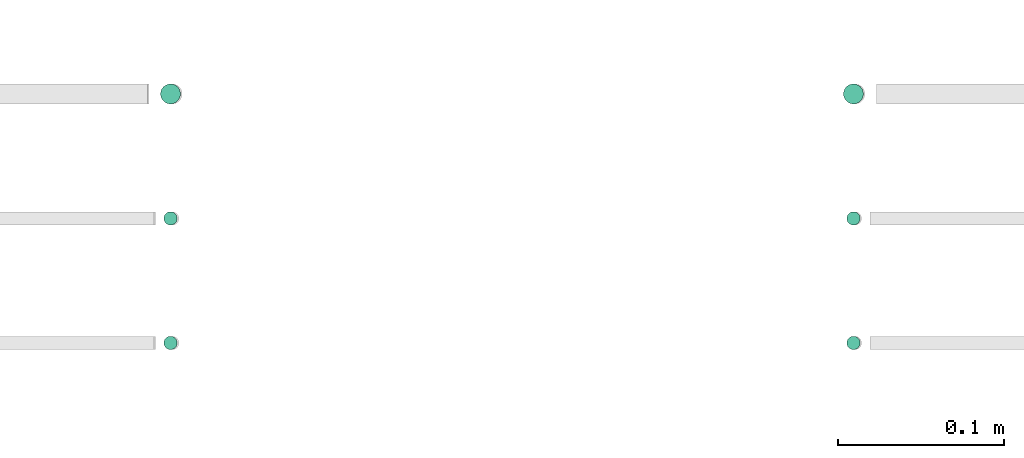
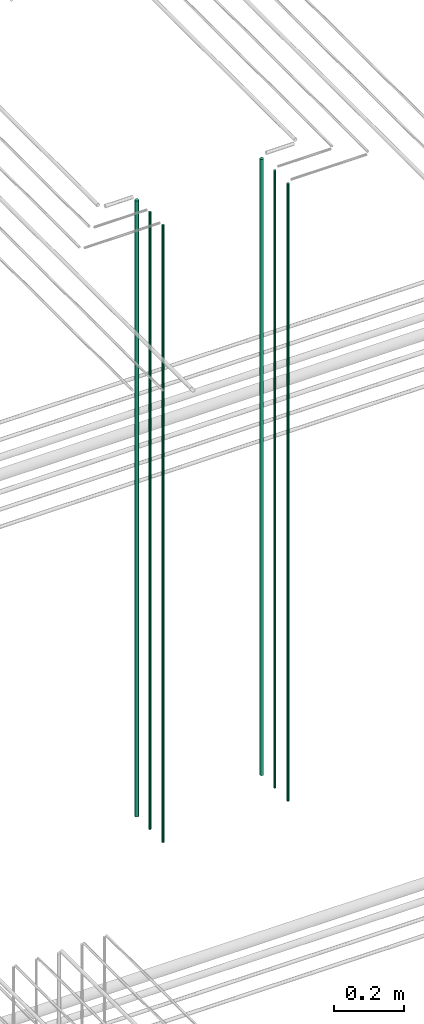
# One storey, part 52 of 331: 6 flow segments.
"""IFC2X3 building model written with IfcOpenShell, lengths in millimetres."""

from ifc_helpers import new_model, entity, si_unit, converted_unit, derived_unit, direction, frame, origin, origin_2d_with_axis, place, context, subcontext, project, spatial, circle, extrude, type_object, element, save


model = new_model("IFC2X3")

# Units and contexts
model_context = context("Model", 3, precision=0.01, world=origin(), true_north=direction((6.12303176911189e-17, 1.0)))
body_context = subcontext(model_context, "Body", "Model", "MODEL_VIEW")
ifc_project = project(units=[si_unit("LENGTHUNIT", "METRE", prefix="MILLI"), si_unit("AREAUNIT", "SQUARE_METRE"), si_unit("VOLUMEUNIT", "CUBIC_METRE"), converted_unit("PLANEANGLEUNIT", "DEGREE", entity("IfcRatioMeasure", 0.0174532925199433), si_unit("PLANEANGLEUNIT", "RADIAN"), dimensions=[0, 0, 0, 0, 0, 0, 0]), si_unit("MASSUNIT", "GRAM", prefix="KILO"), derived_unit("MASSDENSITYUNIT", [(si_unit("MASSUNIT", "GRAM", prefix="KILO"), 1), (si_unit("LENGTHUNIT", "METRE"), -3)]), derived_unit("MOMENTOFINERTIAUNIT", [(si_unit("LENGTHUNIT", "METRE"), 4)]), si_unit("TIMEUNIT", "SECOND"), si_unit("FREQUENCYUNIT", "HERTZ"), si_unit("THERMODYNAMICTEMPERATUREUNIT", "DEGREE_CELSIUS"), derived_unit("THERMALTRANSMITTANCEUNIT", [(si_unit("MASSUNIT", "GRAM", prefix="KILO"), 1), (si_unit("THERMODYNAMICTEMPERATUREUNIT", "KELVIN"), -1), (si_unit("TIMEUNIT", "SECOND"), -3)]), derived_unit("VOLUMETRICFLOWRATEUNIT", [(si_unit("LENGTHUNIT", "METRE"), 3), (si_unit("TIMEUNIT", "SECOND"), -1)]), derived_unit("MASSFLOWRATEUNIT", [(si_unit("MASSUNIT", "GRAM", prefix="KILO"), 1), (si_unit("TIMEUNIT", "SECOND"), -1)]), derived_unit("ROTATIONALFREQUENCYUNIT", [(si_unit("TIMEUNIT", "SECOND"), -1)]), si_unit("ELECTRICCURRENTUNIT", "AMPERE"), si_unit("ELECTRICVOLTAGEUNIT", "VOLT"), si_unit("POWERUNIT", "WATT"), si_unit("FORCEUNIT", "NEWTON", prefix="KILO"), si_unit("ILLUMINANCEUNIT", "LUX"), si_unit("LUMINOUSFLUXUNIT", "LUMEN"), si_unit("LUMINOUSINTENSITYUNIT", "CANDELA"), derived_unit("USERDEFINED", [(si_unit("MASSUNIT", "GRAM", prefix="KILO"), -1), (si_unit("LENGTHUNIT", "METRE"), -2), (si_unit("TIMEUNIT", "SECOND"), 3), (si_unit("LUMINOUSFLUXUNIT", "LUMEN"), 1)]), derived_unit("LINEARVELOCITYUNIT", [(si_unit("LENGTHUNIT", "METRE"), 1), (si_unit("TIMEUNIT", "SECOND"), -1)]), si_unit("PRESSUREUNIT", "PASCAL"), derived_unit("USERDEFINED", [(si_unit("LENGTHUNIT", "METRE"), -2), (si_unit("MASSUNIT", "GRAM", prefix="KILO"), 1), (si_unit("TIMEUNIT", "SECOND"), -2)]), derived_unit("LINEARFORCEUNIT", [(si_unit("MASSUNIT", "GRAM", prefix="KILO"), 1), (si_unit("LENGTHUNIT", "METRE"), 1), (si_unit("TIMEUNIT", "SECOND"), -2), (si_unit("LENGTHUNIT", "METRE"), -1)]), derived_unit("PLANARFORCEUNIT", [(si_unit("MASSUNIT", "GRAM", prefix="KILO"), 1), (si_unit("LENGTHUNIT", "METRE"), 1), (si_unit("TIMEUNIT", "SECOND"), -2), (si_unit("LENGTHUNIT", "METRE"), -2)])], contexts=[model_context])

# Site, building, storey
site_placement = place(None, frame((0.0, -0.00077364408347762, 0.0)))
site = spatial("IfcSite", under=ifc_project, at=site_placement, CompositionType="ELEMENT")
building_placement = place(site_placement, origin())
building = spatial("IfcBuilding", under=site, at=building_placement, CompositionType="ELEMENT")
storey_placement = place(building_placement, origin())
storey = spatial("IfcBuildingStorey", under=building, at=storey_placement, CompositionType="ELEMENT", Elevation=0.0)

# Flow segments
pipe_segment_type = type_object("IfcPipeSegmentType", PredefinedType="NOTDEFINED")
flow_segment_1_placement = place(storey_placement, frame((43956.8310109464, 3883.89349484379, 16890.0)))
element("IfcFlowSegment", 1, at=flow_segment_1_placement, inside=storey, type_object=pipe_segment_type, context=body_context, shape_type="SweptSolid", body=[
    extrude(circle(Radius=6.0, at=origin_2d_with_axis()), frame((7.59527223591454, 7.59527223591616, 0.0)), (0.0, 0.0, 1.0), 2146.0),
])
for number, where in (
    (2, (43958.8310109464, 3735.89349484379, 16890.0)),
    (3, (43958.8310109464, 3810.89349484379, 16890.0)),
):
    element("IfcFlowSegment", number, at=place(storey_placement, frame(where)), inside=storey, type_object=pipe_segment_type, context=body_context, shape_type="SweptSolid", body=[
        extrude(circle(Radius=4.0, at=origin_2d_with_axis()), frame((5.59527223591499, 5.59527223591607, 0.0)), (0.0, 0.0, 1.0), 2150.00000000001),
    ])
flow_segment_2_placement = place(storey_placement, frame((44368.1864417171, 3883.89349484379, 16890.0)))
element("IfcFlowSegment", 4, at=flow_segment_2_placement, inside=storey, type_object=pipe_segment_type, context=body_context, shape_type="SweptSolid", body=[
    extrude(circle(Radius=6.0, at=origin_2d_with_axis()), frame((7.59527223591454, 7.59527223591616, 0.0)), (0.0, 0.0, 1.0), 2146.0),
])
for number, where in (
    (5, (44370.186441717, 3735.89349484379, 16890.0)),
    (6, (44370.186441717, 3810.89349484379, 16890.0)),
):
    element("IfcFlowSegment", number, at=place(storey_placement, frame(where)), inside=storey, type_object=pipe_segment_type, context=body_context, shape_type="SweptSolid", body=[
        extrude(circle(Radius=4.0, at=origin_2d_with_axis()), frame((5.59527223591499, 5.59527223591607, 0.0)), (0.0, 0.0, 1.0), 2150.00000000001),
    ])

save(model, "model.ifc")
